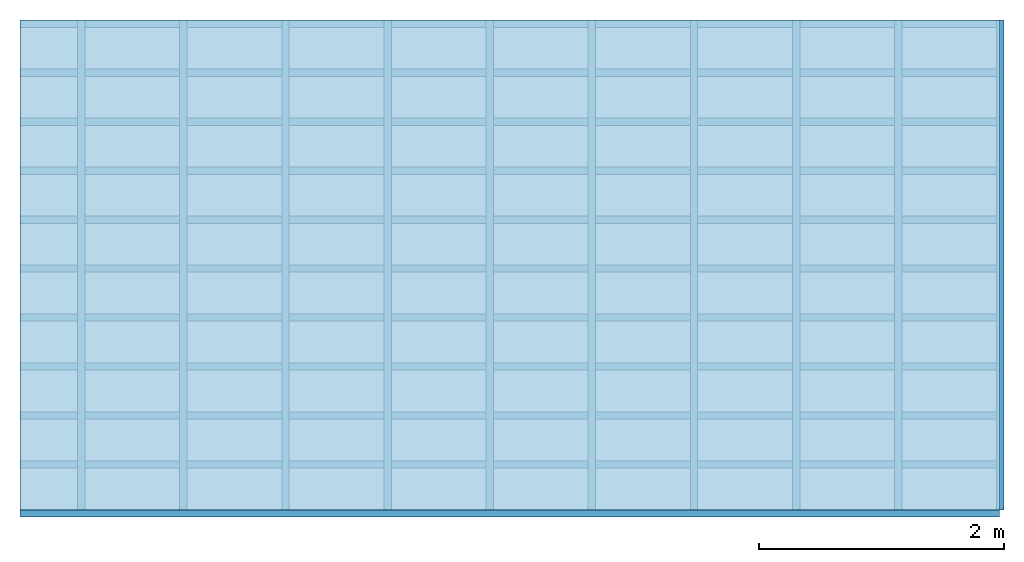
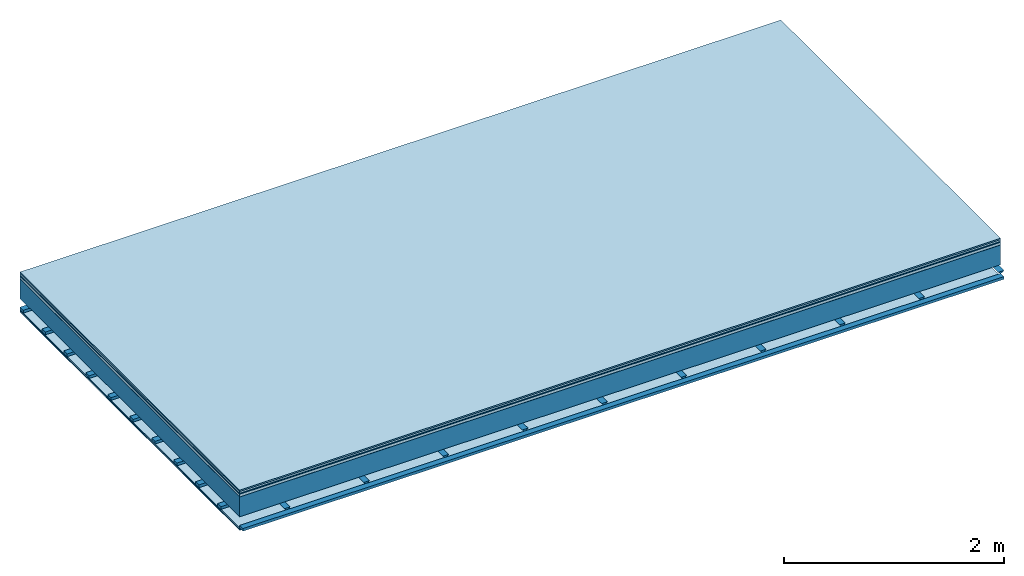
# One storey: 8 plates, 3 members, 1 element without a shape of its own.
"""IFC4 building model written with IfcOpenShell, lengths in metres."""

from ifc_helpers import new_model, si_unit, derived_unit, direction, frame, frame_2d, origin, origin_with_axes, place, context, project, spatial, polyline, rectangle, outline, extrude, material, layer, layer_set, type_object, element, aggregate, save


model = new_model("IFC4")

# Units and contexts
plan_context = context("Plan", 3, precision=1e-05, world=origin(), true_north=direction((0.0, 1.0)))
model_context = context("Model", 3, precision=1e-05, world=origin(), true_north=direction((0.0, 1.0)))
ifc_project = project(units=[si_unit("LENGTHUNIT", "METRE"), derived_unit("SOUNDPRESSUREUNIT", [(si_unit("PRESSUREUNIT", "PASCAL", prefix="MICRO"), 0)]), si_unit("ENERGYUNIT", "JOULE", prefix="MEGA"), si_unit("MASSUNIT", "GRAM", prefix="KILO"), derived_unit("THERMALTRANSMITTANCEUNIT", [(si_unit("POWERUNIT", "WATT"), 1), (si_unit("AREAUNIT", "SQUARE_METRE"), -1), (si_unit("THERMODYNAMICTEMPERATUREUNIT", "KELVIN"), -1)]), derived_unit("AREADENSITYUNIT", [(si_unit("MASSUNIT", "GRAM", prefix="KILO"), 1), (si_unit("AREAUNIT", "SQUARE_METRE"), -1)]), derived_unit("USERDEFINED", [(si_unit("ENERGYUNIT", "JOULE", prefix="MEGA"), 1), (si_unit("AREAUNIT", "SQUARE_METRE"), -1)])], contexts=[plan_context, model_context])

# Site, building, storey
site = spatial("IfcSite", under=ifc_project)
building_placement = place(None, origin())
building = spatial("IfcBuilding", under=site, at=building_placement)
storey_placement = place(building_placement, origin())
storey = spatial("IfcBuildingStorey", under=building, at=storey_placement)

# Slab, members, plates
ifc_material_1 = material(Category="11.013")
ifc_layer_1 = layer(ifc_material_1, 0.015, Name="Flooring")
ifc_material_2 = material(Category="03.007")
ifc_layer_2 = layer(ifc_material_2, 0.02, Name="On-material")
ifc_material_3 = material(Name="Wood fiber generic product", Category="10.009")
ifc_layer_3 = layer(ifc_material_3, 0.01, Name="Impact sound insulation")
ifc_material_4 = material(Name="with broken")
ifc_layer_4 = layer(ifc_material_4, 0.03, Name="on Supporting structure")
ifc_material_5 = material(Name="protection", Category="09.007")
ifc_layer_5 = layer(ifc_material_5, 0.0005, Name="Sub-floor")
ifc_material_6 = material(Name="no composite action")
ifc_layer_6 = layer(ifc_material_6, 0.0, Name="Bond")
ifc_layer_7 = layer(None, 0.22, Name="Supporting structure")
ifc_layer_8 = layer(ifc_material_6, 0.0, Name="Bond")
ifc_layer_9 = layer(None, 0.095, Name="Coupling")
ifc_layer_10 = layer(None, 0.03, Name="Battens / profiles")
ifc_material_7 = material(Name="Plasterboard type A", Category="03.008")
ifc_layer_11 = layer(ifc_material_7, 0.0125, Name="Ceiling covering 1st layer")
ifc_layer_12 = layer(ifc_material_7, 0.0125, Name="Ceiling covering layer 2")
ifc_material_8 = material(Category="04.001")
ifc_layer_13 = layer(ifc_material_8, 0.003, Name="Surface / treatment")
ifc_layer_set = layer_set([ifc_layer_1, ifc_layer_2, ifc_layer_3, ifc_layer_4, ifc_layer_5, ifc_layer_6, ifc_layer_7, ifc_layer_8, ifc_layer_9, ifc_layer_10, ifc_layer_11, ifc_layer_12, ifc_layer_13])
slab_type = type_object("IfcSlabType", Name="A2119", PredefinedType="NOTDEFINED", material=ifc_layer_set)
slab_placement = place(None, frame((0.0, 0.0, 0.0), z_axis=(0.0, 0.0, -1.0), x_axis=(1.0, 0.0, 0.0)))
slab = element("IfcSlab", 1, at=slab_placement, inside=storey, type_object=slab_type, material=ifc_layer_set, Name="Slab #1")
ifc_material_9 = material(Name="Solid timber panel")
member_1_placement = place(slab_placement, origin())
member_1 = element("IfcMember", 2, at=member_1_placement, material=ifc_material_9, Name="Supporting structure", context=plan_context, shape_type="SweptSolid", body=[
    extrude(rectangle(XDim=1.0, YDim=0.22, at=frame_2d((0.5, 0.11), x_axis=(1.0, 0.0))), frame((0.0, 4.0, 0.0755), z_axis=(0.0, -1.0, 0.0), x_axis=(1.0, 0.0, 0.0)), (0.0, 0.0, 1.0), 4.0),
    extrude(rectangle(XDim=1.0, YDim=0.22, at=frame_2d((0.5, 0.11), x_axis=(1.0, 0.0))), frame((1.0, 4.0, 0.0755), z_axis=(0.0, -1.0, 0.0), x_axis=(1.0, 0.0, 0.0)), (0.0, 0.0, 1.0), 4.0),
    extrude(rectangle(XDim=1.0, YDim=0.22, at=frame_2d((0.5, 0.11), x_axis=(1.0, 0.0))), frame((2.0, 4.0, 0.0755), z_axis=(0.0, -1.0, 0.0), x_axis=(1.0, 0.0, 0.0)), (0.0, 0.0, 1.0), 4.0),
    extrude(rectangle(XDim=1.0, YDim=0.22, at=frame_2d((0.5, 0.11), x_axis=(1.0, 0.0))), frame((3.0, 4.0, 0.0755), z_axis=(0.0, -1.0, 0.0), x_axis=(1.0, 0.0, 0.0)), (0.0, 0.0, 1.0), 4.0),
    extrude(rectangle(XDim=1.0, YDim=0.22, at=frame_2d((0.5, 0.11), x_axis=(1.0, 0.0))), frame((4.0, 4.0, 0.0755), z_axis=(0.0, -1.0, 0.0), x_axis=(1.0, 0.0, 0.0)), (0.0, 0.0, 1.0), 4.0),
    extrude(rectangle(XDim=1.0, YDim=0.22, at=frame_2d((0.5, 0.11), x_axis=(1.0, 0.0))), frame((5.0, 4.0, 0.0755), z_axis=(0.0, -1.0, 0.0), x_axis=(1.0, 0.0, 0.0)), (0.0, 0.0, 1.0), 4.0),
    extrude(rectangle(XDim=1.0, YDim=0.22, at=frame_2d((0.5, 0.11), x_axis=(1.0, 0.0))), frame((6.0, 4.0, 0.0755), z_axis=(0.0, -1.0, 0.0), x_axis=(1.0, 0.0, 0.0)), (0.0, 0.0, 1.0), 4.0),
    extrude(rectangle(XDim=1.0, YDim=0.22, at=frame_2d((0.5, 0.11), x_axis=(1.0, 0.0))), frame((7.0, 4.0, 0.0755), z_axis=(0.0, -1.0, 0.0), x_axis=(1.0, 0.0, 0.0)), (0.0, 0.0, 1.0), 4.0),
])
ifc_material_10 = material()
member_2_placement = place(slab_placement, origin())
member_2 = element("IfcMember", 3, at=member_2_placement, material=ifc_material_10, Name="Coupling", context=plan_context, shape_type="SweptSolid", body=[
    extrude(outline(polyline([(0.0, 0.0), (0.06, 0.0), (0.04, 0.02), (0.02, 0.02), (0.0, 0.0)])), frame((0.47, 4.0, 0.3705), z_axis=(0.0, -1.0, 0.0), x_axis=(1.0, 0.0, 0.0)), (0.0, 0.0, 1.0), 4.0),
    extrude(outline(polyline([(0.0, 0.0), (0.06, 0.0), (0.04, 0.02), (0.02, 0.02), (0.0, 0.0)])), frame((1.304, 4.0, 0.3705), z_axis=(0.0, -1.0, 0.0), x_axis=(1.0, 0.0, 0.0)), (0.0, 0.0, 1.0), 4.0),
    extrude(outline(polyline([(0.0, 0.0), (0.06, 0.0), (0.04, 0.02), (0.02, 0.02), (0.0, 0.0)])), frame((2.138, 4.0, 0.3705), z_axis=(0.0, -1.0, 0.0), x_axis=(1.0, 0.0, 0.0)), (0.0, 0.0, 1.0), 4.0),
    extrude(outline(polyline([(0.0, 0.0), (0.06, 0.0), (0.04, 0.02), (0.02, 0.02), (0.0, 0.0)])), frame((2.972, 4.0, 0.3705), z_axis=(0.0, -1.0, 0.0), x_axis=(1.0, 0.0, 0.0)), (0.0, 0.0, 1.0), 4.0),
    extrude(outline(polyline([(0.0, 0.0), (0.06, 0.0), (0.04, 0.02), (0.02, 0.02), (0.0, 0.0)])), frame((3.806, 4.0, 0.3705), z_axis=(0.0, -1.0, 0.0), x_axis=(1.0, 0.0, 0.0)), (0.0, 0.0, 1.0), 4.0),
    extrude(outline(polyline([(0.0, 0.0), (0.06, 0.0), (0.04, 0.02), (0.02, 0.02), (0.0, 0.0)])), frame((4.64, 4.0, 0.3705), z_axis=(0.0, -1.0, 0.0), x_axis=(1.0, 0.0, 0.0)), (0.0, 0.0, 1.0), 4.0),
    extrude(outline(polyline([(0.0, 0.0), (0.06, 0.0), (0.04, 0.02), (0.02, 0.02), (0.0, 0.0)])), frame((5.474, 4.0, 0.3705), z_axis=(0.0, -1.0, 0.0), x_axis=(1.0, 0.0, 0.0)), (0.0, 0.0, 1.0), 4.0),
    extrude(outline(polyline([(0.0, 0.0), (0.06, 0.0), (0.04, 0.02), (0.02, 0.02), (0.0, 0.0)])), frame((6.308, 4.0, 0.3705), z_axis=(0.0, -1.0, 0.0), x_axis=(1.0, 0.0, 0.0)), (0.0, 0.0, 1.0), 4.0),
    extrude(outline(polyline([(0.0, 0.0), (0.06, 0.0), (0.04, 0.02), (0.02, 0.02), (0.0, 0.0)])), frame((7.142, 4.0, 0.3705), z_axis=(0.0, -1.0, 0.0), x_axis=(1.0, 0.0, 0.0)), (0.0, 0.0, 1.0), 4.0),
    extrude(outline(polyline([(0.0, 0.0), (0.06, 0.0), (0.04, 0.02), (0.02, 0.02), (0.0, 0.0)])), frame((7.976, 4.0, 0.3705), z_axis=(0.0, -1.0, 0.0), x_axis=(1.0, 0.0, 0.0)), (0.0, 0.0, 1.0), 4.0),
])
member_3_placement = place(slab_placement, origin())
member_3 = element("IfcMember", 4, at=member_3_placement, material=ifc_material_10, Name="Battens / profiles", context=plan_context, shape_type="SweptSolid", body=[
    extrude(rectangle(XDim=0.06, YDim=0.03, at=frame_2d((0.03, 0.015), x_axis=(1.0, 0.0))), frame((0.0, 0.0, 0.3905), z_axis=(1.0, 0.0, 0.0), x_axis=(0.0, 1.0, 0.0)), (0.0, 0.0, 1.0), 8.0),
    extrude(rectangle(XDim=0.06, YDim=0.03, at=frame_2d((0.03, 0.015), x_axis=(1.0, 0.0))), frame((0.0, 0.4, 0.3905), z_axis=(1.0, 0.0, 0.0), x_axis=(0.0, 1.0, 0.0)), (0.0, 0.0, 1.0), 8.0),
    extrude(rectangle(XDim=0.06, YDim=0.03, at=frame_2d((0.03, 0.015), x_axis=(1.0, 0.0))), frame((0.0, 0.8, 0.3905), z_axis=(1.0, 0.0, 0.0), x_axis=(0.0, 1.0, 0.0)), (0.0, 0.0, 1.0), 8.0),
    extrude(rectangle(XDim=0.06, YDim=0.03, at=frame_2d((0.03, 0.015), x_axis=(1.0, 0.0))), frame((0.0, 1.2, 0.3905), z_axis=(1.0, 0.0, 0.0), x_axis=(0.0, 1.0, 0.0)), (0.0, 0.0, 1.0), 8.0),
    extrude(rectangle(XDim=0.06, YDim=0.03, at=frame_2d((0.03, 0.015), x_axis=(1.0, 0.0))), frame((0.0, 1.6, 0.3905), z_axis=(1.0, 0.0, 0.0), x_axis=(0.0, 1.0, 0.0)), (0.0, 0.0, 1.0), 8.0),
    extrude(rectangle(XDim=0.06, YDim=0.03, at=frame_2d((0.03, 0.015), x_axis=(1.0, 0.0))), frame((0.0, 2.0, 0.3905), z_axis=(1.0, 0.0, 0.0), x_axis=(0.0, 1.0, 0.0)), (0.0, 0.0, 1.0), 8.0),
    extrude(rectangle(XDim=0.06, YDim=0.03, at=frame_2d((0.03, 0.015), x_axis=(1.0, 0.0))), frame((0.0, 2.4, 0.3905), z_axis=(1.0, 0.0, 0.0), x_axis=(0.0, 1.0, 0.0)), (0.0, 0.0, 1.0), 8.0),
    extrude(rectangle(XDim=0.06, YDim=0.03, at=frame_2d((0.03, 0.015), x_axis=(1.0, 0.0))), frame((0.0, 2.8, 0.3905), z_axis=(1.0, 0.0, 0.0), x_axis=(0.0, 1.0, 0.0)), (0.0, 0.0, 1.0), 8.0),
    extrude(rectangle(XDim=0.06, YDim=0.03, at=frame_2d((0.03, 0.015), x_axis=(1.0, 0.0))), frame((0.0, 3.2, 0.3905), z_axis=(1.0, 0.0, 0.0), x_axis=(0.0, 1.0, 0.0)), (0.0, 0.0, 1.0), 8.0),
    extrude(rectangle(XDim=0.06, YDim=0.03, at=frame_2d((0.03, 0.015), x_axis=(1.0, 0.0))), frame((0.0, 3.6, 0.3905), z_axis=(1.0, 0.0, 0.0), x_axis=(0.0, 1.0, 0.0)), (0.0, 0.0, 1.0), 8.0),
    extrude(rectangle(XDim=0.06, YDim=0.03, at=frame_2d((0.03, 0.015), x_axis=(1.0, 0.0))), frame((0.0, 4.0, 0.3905), z_axis=(1.0, 0.0, 0.0), x_axis=(0.0, 1.0, 0.0)), (0.0, 0.0, 1.0), 8.0),
])
plate_1_placement = place(slab_placement, origin())
plate_1 = element("IfcPlate", 5, at=plate_1_placement, material=ifc_material_1, Name="Flooring", context=plan_context, shape_type="SweptSolid", body=[
    extrude(rectangle(XDim=8.0, YDim=4.0, at=frame_2d((4.0, 2.0), x_axis=(1.0, 0.0))), origin_with_axes(), (0.0, 0.0, 1.0), 0.015),
])
plate_2_placement = place(slab_placement, origin())
plate_2 = element("IfcPlate", 6, at=plate_2_placement, material=ifc_material_2, Name="On-material", context=plan_context, shape_type="SweptSolid", body=[
    extrude(rectangle(XDim=8.0, YDim=4.0, at=frame_2d((4.0, 2.0), x_axis=(1.0, 0.0))), frame((0.0, 0.0, 0.015), z_axis=(0.0, 0.0, 1.0), x_axis=(1.0, 0.0, 0.0)), (0.0, 0.0, 1.0), 0.02),
])
plate_3_placement = place(slab_placement, origin())
plate_3 = element("IfcPlate", 7, at=plate_3_placement, material=ifc_material_3, Name="Impact sound insulation", context=plan_context, shape_type="SweptSolid", body=[
    extrude(rectangle(XDim=8.0, YDim=4.0, at=frame_2d((4.0, 2.0), x_axis=(1.0, 0.0))), frame((0.0, 0.0, 0.035), z_axis=(0.0, 0.0, 1.0), x_axis=(1.0, 0.0, 0.0)), (0.0, 0.0, 1.0), 0.01),
])
plate_4_placement = place(slab_placement, origin())
plate_4 = element("IfcPlate", 8, at=plate_4_placement, material=ifc_material_4, Name="on Supporting structure", context=plan_context, shape_type="SweptSolid", body=[
    extrude(rectangle(XDim=8.0, YDim=4.0, at=frame_2d((4.0, 2.0), x_axis=(1.0, 0.0))), frame((0.0, 0.0, 0.045), z_axis=(0.0, 0.0, 1.0), x_axis=(1.0, 0.0, 0.0)), (0.0, 0.0, 1.0), 0.03),
])
plate_5_placement = place(slab_placement, origin())
plate_5 = element("IfcPlate", 9, at=plate_5_placement, material=ifc_material_5, Name="Sub-floor", context=plan_context, shape_type="SweptSolid", body=[
    extrude(rectangle(XDim=8.0, YDim=4.0, at=frame_2d((4.0, 2.0), x_axis=(1.0, 0.0))), frame((0.0, 0.0, 0.075), z_axis=(0.0, 0.0, 1.0), x_axis=(1.0, 0.0, 0.0)), (0.0, 0.0, 1.0), 0.0005),
])
plate_6_placement = place(slab_placement, origin())
plate_6 = element("IfcPlate", 10, at=plate_6_placement, material=ifc_material_7, Name="Ceiling covering 1st layer", context=plan_context, shape_type="SweptSolid", body=[
    extrude(rectangle(XDim=8.0, YDim=4.0, at=frame_2d((4.0, 2.0), x_axis=(1.0, 0.0))), frame((0.0, 0.0, 0.4205), z_axis=(0.0, 0.0, 1.0), x_axis=(1.0, 0.0, 0.0)), (0.0, 0.0, 1.0), 0.0125),
])
plate_7_placement = place(slab_placement, origin())
plate_7 = element("IfcPlate", 11, at=plate_7_placement, material=ifc_material_7, Name="Ceiling covering layer 2", context=plan_context, shape_type="SweptSolid", body=[
    extrude(rectangle(XDim=8.0, YDim=4.0, at=frame_2d((4.0, 2.0), x_axis=(1.0, 0.0))), frame((0.0, 0.0, 0.433), z_axis=(0.0, 0.0, 1.0), x_axis=(1.0, 0.0, 0.0)), (0.0, 0.0, 1.0), 0.0125),
])
plate_8_placement = place(slab_placement, origin())
plate_8 = element("IfcPlate", 12, at=plate_8_placement, material=ifc_material_8, Name="Surface / treatment", context=plan_context, shape_type="SweptSolid", body=[
    extrude(rectangle(XDim=8.0, YDim=4.0, at=frame_2d((4.0, 2.0), x_axis=(1.0, 0.0))), frame((0.0, 0.0, 0.4455), z_axis=(0.0, 0.0, 1.0), x_axis=(1.0, 0.0, 0.0)), (0.0, 0.0, 1.0), 0.003),
])
aggregate(slab, [plate_1, plate_2, plate_3, plate_4, plate_5, member_1, member_2, member_3, plate_6, plate_7, plate_8])

save(model, "model.ifc")
